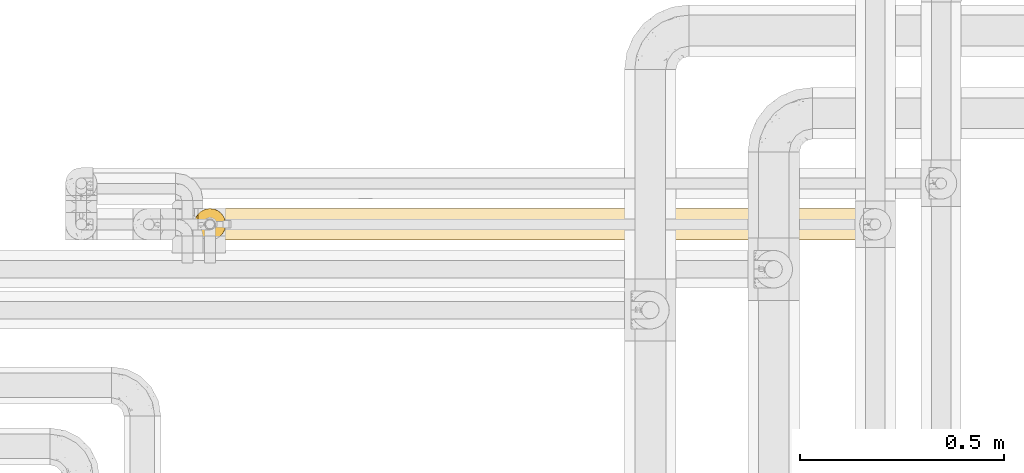
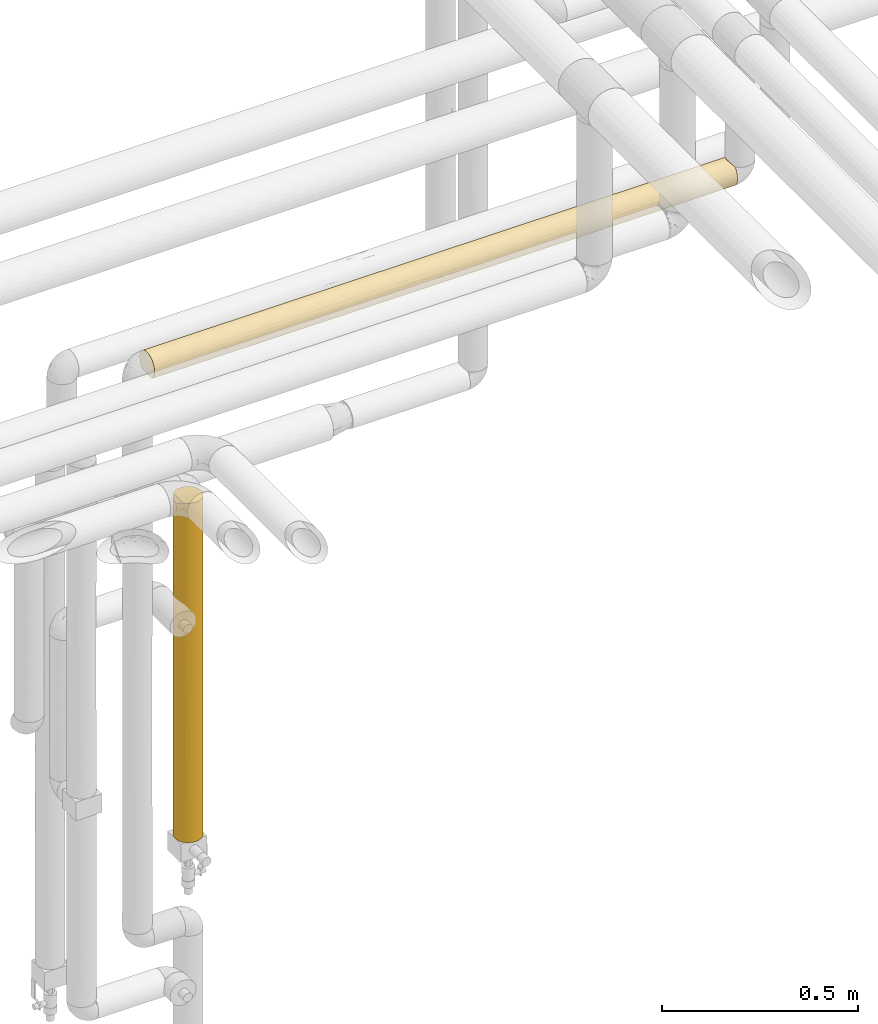
# One storey, part 42 of 827: 2 coverings.
"""IFC2X3 building model written with IfcOpenShell, lengths in millimetres."""

from ifc_helpers import new_model, entity, si_unit, converted_unit, derived_unit, direction, frame, origin, place, context, subcontext, project, spatial, faceted_brep, element, save


model = new_model("IFC2X3")

# Units and contexts
model_context = context("Model", 3, precision=0.01, world=origin(), true_north=direction((6.12303176911189e-17, 1.0)))
body_context = subcontext(model_context, "Body", "Model", "MODEL_VIEW")
ifc_project = project(units=[si_unit("LENGTHUNIT", "METRE", prefix="MILLI"), si_unit("AREAUNIT", "SQUARE_METRE"), si_unit("VOLUMEUNIT", "CUBIC_METRE"), converted_unit("PLANEANGLEUNIT", "DEGREE", entity("IfcRatioMeasure", 0.0174532925199433), si_unit("PLANEANGLEUNIT", "RADIAN"), dimensions=[0, 0, 0, 0, 0, 0, 0]), si_unit("MASSUNIT", "GRAM", prefix="KILO"), derived_unit("MASSDENSITYUNIT", [(si_unit("MASSUNIT", "GRAM", prefix="KILO"), 1), (si_unit("LENGTHUNIT", "METRE"), -3)]), derived_unit("MOMENTOFINERTIAUNIT", [(si_unit("LENGTHUNIT", "METRE"), 4)]), si_unit("TIMEUNIT", "SECOND"), si_unit("FREQUENCYUNIT", "HERTZ"), si_unit("THERMODYNAMICTEMPERATUREUNIT", "DEGREE_CELSIUS"), derived_unit("THERMALTRANSMITTANCEUNIT", [(si_unit("MASSUNIT", "GRAM", prefix="KILO"), 1), (si_unit("THERMODYNAMICTEMPERATUREUNIT", "KELVIN"), -1), (si_unit("TIMEUNIT", "SECOND"), -3)]), derived_unit("VOLUMETRICFLOWRATEUNIT", [(si_unit("LENGTHUNIT", "METRE"), 3), (si_unit("TIMEUNIT", "SECOND"), -1)]), derived_unit("MASSFLOWRATEUNIT", [(si_unit("MASSUNIT", "GRAM", prefix="KILO"), 1), (si_unit("TIMEUNIT", "SECOND"), -1)]), derived_unit("ROTATIONALFREQUENCYUNIT", [(si_unit("TIMEUNIT", "SECOND"), -1)]), si_unit("ELECTRICCURRENTUNIT", "AMPERE"), si_unit("ELECTRICVOLTAGEUNIT", "VOLT"), si_unit("POWERUNIT", "WATT"), si_unit("FORCEUNIT", "NEWTON", prefix="KILO"), si_unit("ILLUMINANCEUNIT", "LUX"), si_unit("LUMINOUSFLUXUNIT", "LUMEN"), si_unit("LUMINOUSINTENSITYUNIT", "CANDELA"), derived_unit("USERDEFINED", [(si_unit("MASSUNIT", "GRAM", prefix="KILO"), -1), (si_unit("LENGTHUNIT", "METRE"), -2), (si_unit("TIMEUNIT", "SECOND"), 3), (si_unit("LUMINOUSFLUXUNIT", "LUMEN"), 1)]), derived_unit("LINEARVELOCITYUNIT", [(si_unit("LENGTHUNIT", "METRE"), 1), (si_unit("TIMEUNIT", "SECOND"), -1)]), si_unit("PRESSUREUNIT", "PASCAL"), derived_unit("USERDEFINED", [(si_unit("LENGTHUNIT", "METRE"), -2), (si_unit("MASSUNIT", "GRAM", prefix="KILO"), 1), (si_unit("TIMEUNIT", "SECOND"), -2)]), derived_unit("LINEARFORCEUNIT", [(si_unit("MASSUNIT", "GRAM", prefix="KILO"), 1), (si_unit("LENGTHUNIT", "METRE"), 1), (si_unit("TIMEUNIT", "SECOND"), -2), (si_unit("LENGTHUNIT", "METRE"), -1)]), derived_unit("PLANARFORCEUNIT", [(si_unit("MASSUNIT", "GRAM", prefix="KILO"), 1), (si_unit("LENGTHUNIT", "METRE"), 1), (si_unit("TIMEUNIT", "SECOND"), -2), (si_unit("LENGTHUNIT", "METRE"), -2)])], contexts=[model_context])

# Site, building, storey
site_placement = place(None, origin())
site = spatial("IfcSite", under=ifc_project, at=site_placement, CompositionType="ELEMENT")
building_placement = place(site_placement, origin())
building = spatial("IfcBuilding", under=site, at=building_placement, CompositionType="ELEMENT")
storey_placement = place(building_placement, frame((0.0, 0.0, 28200.0)))
storey = spatial("IfcBuildingStorey", under=building, at=storey_placement, Name="08", CompositionType="ELEMENT", Elevation=28200.0)

# Coverings
covering_1_placement = place(storey_placement, frame((34717.93, 18294.92, 2960.17)))
element("IfcCovering", 1, at=covering_1_placement, inside=storey, Name=":ADSK_", ObjectType=":ADSK_", PredefinedType="INSULATION", context=body_context, shape_type="Brep", body=[
    faceted_brep([(1721.69, 59.2, 6.74), (1721.69, 67.15, 12.84), (1721.69, 73.25, 20.8), (1721.69, 77.09, 30.06), (1721.69, 78.4, 40.0), (1721.69, 77.51, 48.2), (1721.69, 74.9, 56.01), (1721.69, 70.68, 63.08), (1721.69, 65.05, 69.1), (1721.69, 14.94, 69.1), (1721.69, 9.31, 63.08), (1721.69, 5.09, 56.01), (1721.69, 2.48, 48.2), (1721.69, 1.6, 40.0), (1721.69, 2.9, 30.06), (1721.69, 6.74, 20.8), (1721.69, 12.84, 12.84), (1721.69, 20.8, 6.74), (1721.69, 30.06, 2.9), (1721.69, 40.0, 1.6), (1721.69, 49.93, 2.9), (1.6, 77.09, 49.93), (1.6, 78.4, 40.0), (1.6, 77.51, 31.79), (1.6, 74.9, 23.98), (1.6, 70.68, 16.91), (1.6, 65.05, 10.9), (1.6, 14.94, 10.9), (1.6, 9.31, 16.91), (1.6, 5.09, 23.98), (1.6, 2.48, 31.79), (1.6, 1.6, 40.0), (1.6, 2.9, 49.93), (1.6, 6.74, 59.2), (1.6, 12.84, 67.15), (1.6, 20.8, 73.25), (1.6, 30.06, 77.09), (1.6, 40.0, 78.4), (1.6, 49.93, 77.09), (1.6, 59.2, 73.25), (1.6, 67.15, 67.15), (1.6, 73.25, 59.2), (218.66, 7.01, 20.33), (1181.65, 9.53, 16.62), (1471.1, 9.53, 16.62), (1393.39, 4.52, 25.3), (1402.18, 32.68, 2.3), (1299.04, 40.0, 1.6), (1505.31, 40.0, 1.6), (287.23, 3.58, 27.82), (217.97, 1.6, 40.0), (616.82, 2.85, 30.25), (434.34, 1.6, 40.0), (977.76, 14.18, 11.57), (743.65, 9.87, 16.18), (717.19, 17.22, 9.08), (287.24, 11.96, 13.75), (335.45, 31.75, 2.49), (688.07, 29.53, 3.05), (384.99, 23.31, 5.41), (1199.89, 3.98, 26.66), (939.49, 22.16, 5.99), (1397.13, 2.24, 32.96), (1161.95, 2.21, 33.16), (485.18, 7.01, 20.33), (227.27, 40.0, 1.6), (10.29, 33.21, 2.2), (982.05, 31.09, 2.64), (1187.22, 33.38, 2.17), (1199.75, 25.3, 4.52), (532.41, 12.87, 12.82), (5.57, 20.48, 6.92), (8.5, 26.63, 4.0), (606.06, 22.88, 5.62), (383.25, 16.94, 9.29), (1400.42, 16.62, 9.53), (1480.82, 25.3, 4.52), (1505.31, 1.6, 40.0), (443.64, 40.0, 1.6), (1288.94, 1.6, 40.0), (867.09, 1.6, 40.0), (1002.96, 3.74, 27.35), (10.9, 40.0, 1.6), (1167.6, 18.11, 8.44), (660.01, 40.0, 1.6), (876.39, 40.0, 1.6), (705.79, 5.53, 23.07), (856.2, 1.6, 40.0), (650.71, 1.6, 40.0), (645.28, 1.6, 40.0), (1087.71, 40.0, 1.6), (961.54, 9.06, 17.25), (1078.01, 1.6, 40.0), (1072.57, 1.6, 40.0), (335.45, 48.24, 2.49), (688.07, 50.46, 3.05), (287.24, 68.03, 13.75), (383.25, 63.05, 9.29), (218.66, 72.98, 20.33), (1400.42, 63.37, 9.53), (8.5, 53.36, 4.0), (5.57, 59.51, 6.92), (384.99, 56.68, 5.41), (10.29, 46.78, 2.2), (1161.95, 77.78, 33.16), (1288.94, 78.4, 40.0), (1397.13, 77.75, 32.96), (485.18, 72.98, 20.33), (287.23, 76.41, 27.82), (1480.82, 54.69, 4.52), (1402.18, 47.31, 2.3), (1199.75, 54.69, 4.52), (1471.1, 70.46, 16.62), (1393.39, 75.47, 25.3), (1190.71, 47.68, 2.37), (743.65, 70.12, 16.18), (532.41, 67.12, 12.82), (717.19, 62.77, 9.08), (977.76, 65.82, 11.57), (616.82, 77.14, 30.25), (867.09, 78.4, 40.0), (1072.57, 78.4, 40.0), (1078.01, 78.4, 40.0), (939.49, 57.83, 5.99), (1194.8, 65.31, 11.12), (434.34, 78.4, 40.0), (217.97, 78.4, 40.0), (958.41, 72.6, 19.72), (1199.89, 76.01, 26.66), (1181.65, 70.46, 16.62), (1505.31, 78.4, 40.0), (606.06, 57.11, 5.62), (982.05, 48.9, 2.64), (705.79, 74.47, 23.07), (645.27, 78.4, 40.0), (650.72, 78.4, 40.0), (856.19, 78.4, 40.0), (1002.96, 76.25, 27.35), (252.19, 70.46, 63.37), (329.89, 75.47, 54.69), (1340.03, 63.05, 70.7), (1436.04, 68.03, 66.24), (1190.88, 67.12, 67.17), (523.53, 54.69, 75.47), (321.11, 47.31, 77.69), (532.57, 47.68, 77.62), (783.79, 57.83, 74.0), (528.49, 65.31, 68.87), (242.46, 54.69, 75.47), (322.86, 63.37, 70.46), (1387.83, 48.24, 77.5), (1714.79, 53.36, 76.0), (1338.29, 56.68, 74.58), (1436.05, 76.41, 52.17), (1238.1, 72.98, 59.66), (979.63, 70.12, 63.81), (561.33, 77.78, 46.83), (1504.62, 72.98, 59.66), (326.15, 77.75, 47.03), (1063.27, 40.0, 78.4), (1279.64, 40.0, 78.4), (1035.22, 50.46, 76.94), (846.9, 40.0, 78.4), (1006.09, 62.77, 70.91), (745.52, 65.82, 68.42), (1712.99, 46.78, 77.79), (217.97, 40.0, 78.4), (1717.72, 59.51, 73.07), (1106.47, 77.14, 49.74), (1496.02, 40.0, 78.4), (1712.39, 40.0, 78.4), (764.87, 72.6, 60.27), (523.39, 76.01, 53.33), (541.63, 70.46, 63.37), (635.57, 40.0, 78.4), (424.25, 40.0, 78.4), (1117.22, 57.11, 74.37), (741.23, 48.9, 77.35), (1017.49, 74.47, 56.92), (720.32, 76.25, 52.64), (242.46, 25.3, 75.47), (326.15, 2.24, 47.03), (741.23, 31.09, 77.35), (536.06, 33.38, 77.82), (523.53, 25.3, 75.47), (783.79, 22.16, 74.0), (1035.22, 29.53, 76.94), (541.63, 9.53, 63.37), (252.19, 9.53, 63.37), (329.89, 4.52, 54.69), (1340.03, 16.94, 70.7), (1717.72, 20.48, 73.07), (1338.29, 23.31, 74.58), (322.86, 16.62, 70.46), (1714.79, 26.63, 76.0), (1387.83, 31.75, 77.5), (1712.99, 33.21, 77.79), (321.11, 32.68, 77.69), (1436.04, 11.96, 66.24), (1504.62, 7.01, 59.66), (1238.1, 7.01, 59.66), (1436.05, 3.58, 52.17), (1117.22, 22.88, 74.37), (523.39, 3.98, 53.33), (1006.09, 17.22, 70.91), (979.63, 9.87, 63.81), (1190.88, 12.87, 67.17), (745.52, 14.18, 68.42), (1106.47, 2.85, 49.74), (561.33, 2.21, 46.83), (720.32, 3.74, 52.64), (555.69, 18.11, 71.55), (1017.49, 5.53, 56.92), (761.75, 9.06, 62.74)], [[[0, 1, 2, 3, 4, 5, 6, 7, 8, 9, 10, 11, 12, 13, 14, 15, 16, 17, 18, 19, 20]], [[21, 22, 23, 24, 25, 26, 27, 28, 29, 30, 31, 32, 33, 34, 35, 36, 37, 38, 39, 40, 41]], [[42, 29, 28]], [[43, 44, 45]], [[46, 47, 48]], [[49, 50, 30]], [[49, 51, 52]], [[53, 54, 55]], [[56, 42, 28]], [[57, 58, 59]], [[45, 60, 43]], [[55, 61, 53]], [[60, 62, 63]], [[15, 14, 45]], [[42, 64, 49]], [[29, 49, 30]], [[65, 57, 66]], [[16, 15, 44]], [[67, 68, 69]], [[27, 56, 28]], [[55, 54, 70]], [[59, 71, 72]], [[61, 73, 58]], [[59, 74, 71]], [[61, 58, 67]], [[75, 69, 76]], [[76, 18, 17]], [[17, 16, 75]], [[14, 13, 77]], [[65, 78, 57]], [[74, 27, 71]], [[72, 66, 57]], [[74, 55, 70]], [[51, 49, 64]], [[45, 44, 15]], [[62, 77, 79]], [[63, 80, 81]], [[66, 82, 65]], [[44, 75, 16]], [[18, 48, 19]], [[43, 53, 83]], [[58, 78, 84, 85]], [[57, 59, 72]], [[61, 67, 69]], [[73, 59, 58]], [[51, 81, 80]], [[56, 70, 64]], [[64, 54, 86]], [[51, 80, 87, 88, 89, 52]], [[50, 49, 52]], [[50, 31, 30]], [[75, 44, 43]], [[75, 76, 17]], [[46, 18, 76]], [[90, 68, 67]], [[18, 46, 48]], [[69, 46, 76]], [[90, 67, 85]], [[46, 68, 47]], [[58, 85, 67]], [[69, 75, 83]], [[61, 55, 73]], [[61, 69, 83]], [[91, 54, 53]], [[91, 53, 43]], [[64, 86, 51]], [[63, 62, 79]], [[77, 62, 14]], [[14, 62, 45]], [[63, 79, 92, 93, 80]], [[60, 63, 81]], [[60, 81, 91]], [[62, 60, 45]], [[64, 70, 54]], [[74, 70, 56]], [[74, 56, 27]], [[74, 59, 73]], [[91, 86, 54]], [[81, 51, 86]], [[64, 42, 56]], [[29, 42, 49]], [[78, 58, 57]], [[74, 73, 55]], [[47, 68, 90]], [[69, 68, 46]], [[43, 83, 75]], [[61, 83, 53]], [[60, 91, 43]], [[86, 91, 81]], [[78, 94, 95]], [[96, 97, 26]], [[25, 98, 96]], [[0, 99, 1]], [[25, 96, 26]], [[100, 101, 102]], [[103, 100, 94]], [[104, 105, 106]], [[107, 96, 98]], [[108, 98, 24]], [[20, 19, 48]], [[94, 100, 102]], [[109, 110, 111]], [[2, 112, 113]], [[109, 99, 0]], [[111, 110, 114]], [[107, 115, 116]], [[84, 78, 95, 85]], [[65, 82, 103]], [[113, 3, 2]], [[108, 24, 23]], [[0, 20, 109]], [[117, 115, 118]], [[97, 96, 116]], [[2, 1, 112]], [[107, 108, 119]], [[106, 3, 113]], [[104, 120, 121, 122, 105]], [[123, 124, 111]], [[125, 108, 126]], [[78, 65, 94]], [[97, 101, 26]], [[108, 23, 126]], [[119, 108, 125]], [[127, 128, 129]], [[3, 130, 4]], [[124, 123, 118]], [[90, 114, 47]], [[99, 124, 112]], [[103, 94, 65]], [[94, 102, 95]], [[102, 131, 95]], [[132, 123, 111]], [[127, 118, 115]], [[115, 107, 133]], [[119, 125, 134, 135, 136, 120]], [[137, 119, 120]], [[23, 22, 126]], [[99, 112, 1]], [[113, 112, 129]], [[48, 110, 20]], [[99, 109, 111]], [[110, 48, 47]], [[132, 90, 85]], [[20, 110, 109]], [[132, 111, 114]], [[85, 95, 132]], [[95, 131, 123]], [[95, 123, 132]], [[118, 123, 117]], [[117, 116, 115]], [[124, 118, 129]], [[133, 107, 119]], [[127, 137, 128]], [[3, 106, 130]], [[105, 130, 106]], [[104, 128, 137]], [[128, 106, 113]], [[120, 104, 137]], [[106, 128, 104]], [[129, 128, 113]], [[117, 131, 97]], [[107, 116, 96]], [[117, 97, 116]], [[101, 97, 102]], [[119, 137, 133]], [[127, 133, 137]], [[24, 98, 25]], [[107, 98, 108]], [[97, 131, 102]], [[123, 131, 117]], [[47, 114, 110]], [[90, 132, 114]], [[112, 124, 129]], [[111, 124, 99]], [[118, 127, 129]], [[133, 127, 115]], [[41, 40, 138]], [[41, 138, 139]], [[140, 141, 142]], [[143, 144, 145]], [[146, 147, 143]], [[39, 148, 149]], [[150, 151, 152]], [[139, 21, 41]], [[105, 153, 130]], [[154, 155, 142]], [[156, 136, 135, 134, 125]], [[154, 141, 157]], [[148, 39, 38]], [[156, 125, 158]], [[153, 157, 6]], [[159, 160, 161, 162]], [[163, 155, 164]], [[165, 151, 150]], [[158, 21, 139]], [[141, 140, 8]], [[38, 37, 166]], [[7, 157, 141]], [[150, 161, 160]], [[7, 141, 8]], [[167, 152, 151]], [[39, 149, 40]], [[154, 153, 168]], [[148, 144, 143]], [[169, 170, 165]], [[153, 6, 5]], [[160, 169, 150]], [[140, 167, 8]], [[153, 5, 130]], [[168, 153, 105]], [[171, 172, 173]], [[21, 126, 22]], [[147, 146, 164]], [[174, 145, 175]], [[149, 147, 138]], [[165, 150, 169]], [[150, 152, 161]], [[152, 176, 161]], [[177, 146, 143]], [[171, 164, 155]], [[155, 154, 178]], [[168, 105, 122, 121, 120, 136]], [[179, 168, 136]], [[5, 4, 130]], [[149, 138, 40]], [[139, 138, 173]], [[166, 144, 38]], [[149, 148, 143]], [[144, 166, 175]], [[177, 174, 162]], [[38, 144, 148]], [[177, 143, 145]], [[162, 161, 177]], [[161, 176, 146]], [[161, 146, 177]], [[164, 146, 163]], [[163, 142, 155]], [[147, 164, 173]], [[178, 154, 168]], [[171, 179, 172]], [[21, 158, 126]], [[125, 126, 158]], [[156, 172, 179]], [[172, 158, 139]], [[136, 156, 179]], [[158, 172, 156]], [[173, 172, 139]], [[163, 176, 140]], [[154, 142, 141]], [[163, 140, 142]], [[167, 140, 152]], [[168, 179, 178]], [[171, 178, 179]], [[6, 157, 7]], [[154, 157, 153]], [[140, 176, 152]], [[146, 176, 163]], [[175, 145, 144]], [[174, 177, 145]], [[138, 147, 173]], [[143, 147, 149]], [[164, 171, 173]], [[178, 171, 155]], [[35, 180, 36]], [[52, 181, 50]], [[182, 183, 184]], [[185, 186, 182]], [[187, 188, 189]], [[190, 191, 192]], [[193, 184, 180]], [[191, 194, 192]], [[34, 33, 188]], [[169, 195, 196]], [[197, 175, 166]], [[9, 198, 10]], [[199, 200, 201]], [[201, 77, 12]], [[195, 186, 192]], [[185, 202, 186]], [[190, 9, 191]], [[189, 203, 187]], [[194, 196, 195]], [[198, 199, 10]], [[204, 205, 206]], [[207, 205, 204]], [[11, 201, 12]], [[204, 185, 207]], [[199, 11, 10]], [[201, 208, 79]], [[33, 32, 189]], [[169, 160, 195]], [[35, 34, 193]], [[209, 203, 181]], [[190, 204, 206]], [[208, 201, 200]], [[12, 77, 13]], [[32, 50, 181]], [[209, 87, 210]], [[196, 170, 169]], [[188, 193, 34]], [[36, 166, 37]], [[187, 207, 211]], [[186, 160, 159, 162]], [[195, 192, 194]], [[185, 182, 184]], [[202, 192, 186]], [[208, 210, 87]], [[198, 206, 200]], [[200, 205, 212]], [[208, 87, 80, 93, 92, 79]], [[189, 188, 33]], [[79, 77, 201]], [[193, 188, 187]], [[193, 180, 35]], [[197, 36, 180]], [[174, 183, 182]], [[36, 197, 166]], [[184, 197, 180]], [[174, 182, 162]], [[197, 183, 175]], [[186, 162, 182]], [[184, 193, 211]], [[185, 204, 202]], [[185, 184, 211]], [[213, 205, 207]], [[213, 207, 187]], [[200, 212, 208]], [[32, 31, 50]], [[209, 181, 52]], [[32, 181, 189]], [[209, 52, 89, 88, 87]], [[203, 209, 210]], [[203, 210, 213]], [[181, 203, 189]], [[200, 206, 205]], [[190, 206, 198]], [[190, 198, 9]], [[190, 192, 202]], [[213, 212, 205]], [[210, 208, 212]], [[200, 199, 198]], [[11, 199, 201]], [[160, 186, 195]], [[190, 202, 204]], [[175, 183, 174]], [[184, 183, 197]], [[187, 211, 193]], [[185, 211, 207]], [[203, 213, 187]], [[212, 213, 210]], [[165, 170, 196, 194, 191, 9, 8, 167, 151]], [[26, 101, 100, 103, 82, 66, 72, 71, 27]]]),
])
covering_2_placement = place(storey_placement, frame((34800.43, 18294.92, 1492.5)))
element("IfcCovering", 2, at=covering_2_placement, inside=storey, Name=":ADSK_", ObjectType=":ADSK_", PredefinedType="INSULATION", context=body_context, shape_type="Brep", body=[
    faceted_brep([(2.9, 30.06, 0.0), (1.6, 40.0, 0.0), (2.9, 49.93, 0.0), (6.74, 59.2, 0.0), (12.84, 67.15, 0.0), (20.8, 73.25, 0.0), (30.06, 77.09, 0.0), (40.0, 78.4, 0.0), (49.93, 77.09, 0.0), (59.2, 73.25, 0.0), (67.15, 67.15, 0.0), (73.25, 59.2, 0.0), (77.09, 49.93, 0.0), (78.4, 40.0, 0.0), (77.09, 30.06, 0.0), (73.25, 20.8, 0.0), (67.15, 12.84, 0.0), (59.2, 6.74, 0.0), (49.93, 2.9, 0.0), (40.0, 1.6, 0.0), (30.06, 2.9, 0.0), (20.8, 6.74, 0.0), (12.84, 12.84, 0.0), (6.74, 20.8, 0.0), (10.9, 14.94, 1058.4), (16.91, 9.31, 1058.4), (23.98, 5.09, 1058.4), (31.79, 2.48, 1058.4), (40.0, 1.6, 1058.4), (49.93, 2.9, 1058.4), (59.2, 6.74, 1058.4), (67.15, 12.84, 1058.4), (73.25, 20.8, 1058.4), (77.09, 30.06, 1058.4), (78.4, 40.0, 1058.4), (77.09, 49.93, 1058.4), (73.25, 59.2, 1058.4), (67.15, 67.15, 1058.4), (59.2, 73.25, 1058.4), (49.93, 77.09, 1058.4), (40.0, 78.4, 1058.4), (31.79, 77.51, 1058.4), (23.98, 74.9, 1058.4), (16.91, 70.68, 1058.4), (10.9, 65.05, 1058.4), (70.46, 16.62, 813.62), (78.4, 40.0, 312.83), (77.64, 32.43, 237.31), (75.01, 24.24, 875.18), (76.93, 29.5, 733.84), (78.4, 40.0, 842.03), (70.46, 16.62, 244.78), (47.2, 2.28, 733.84), (46.91, 2.22, 494.82), (54.69, 4.52, 446.97), (78.4, 40.0, 625.65), (74.0, 22.15, 671.41), (77.68, 32.64, 469.24), (75.47, 25.3, 324.07), (70.46, 16.62, 529.2), (63.37, 9.53, 734.33), (40.0, 1.6, 625.65), (63.37, 9.53, 293.9), (56.85, 5.49, 225.61), (54.69, 4.52, 799.25), (65.03, 10.88, 514.11), (49.37, 2.76, 252.44), (40.0, 1.6, 842.03), (40.0, 1.6, 432.75), (40.0, 1.6, 312.83), (40.0, 1.6, 216.37), (20.33, 7.01, 855.36), (27.82, 3.58, 790.86), (20.33, 7.01, 620.07), (14.36, 11.4, 737.71), (14.56, 11.23, 498.2), (25.3, 4.52, 313.84), (2.98, 29.79, 742.51), (2.33, 32.52, 462.27), (4.6, 25.11, 549.47), (16.62, 9.53, 257.2), (8.89, 17.48, 800.36), (2.2, 33.21, 1049.7), (1.6, 40.0, 832.73), (32.83, 2.27, 308.29), (2.33, 32.5, 231.69), (1.6, 40.0, 308.18), (31.06, 2.65, 529.2), (4.0, 26.63, 1051.5), (5.45, 23.23, 742.57), (9.53, 16.62, 243.7), (4.52, 25.3, 309.55), (9.0, 17.32, 526.07), (1.6, 40.0, 616.36), (1.6, 40.0, 432.75), (6.92, 20.48, 1054.43), (1.6, 40.0, 216.37), (1.6, 40.0, 1049.1), (5.36, 56.59, 867.73), (4.0, 53.36, 1051.5), (6.92, 59.51, 1054.43), (2.2, 46.78, 1049.7), (2.98, 50.2, 742.51), (4.52, 54.69, 309.55), (9.53, 63.37, 243.7), (8.89, 62.51, 800.36), (2.25, 47.04, 324.56), (3.31, 51.35, 515.31), (9.0, 62.67, 526.07), (14.36, 68.59, 737.71), (20.33, 72.98, 855.36), (40.0, 78.4, 625.65), (40.0, 78.4, 432.74), (31.06, 77.34, 529.2), (27.82, 76.41, 790.86), (5.63, 57.12, 658.7), (20.33, 72.98, 620.07), (40.0, 78.4, 216.37), (32.83, 77.72, 308.29), (25.3, 75.47, 313.84), (16.62, 70.46, 257.2), (40.0, 78.4, 842.02), (14.56, 68.76, 498.2), (40.0, 78.4, 745.57), (63.37, 70.46, 813.62), (54.69, 75.47, 734.33), (63.37, 70.46, 244.78), (70.46, 63.37, 293.9), (69.11, 65.03, 514.11), (75.47, 54.69, 446.97), (54.69, 75.47, 324.07), (56.97, 74.44, 529.2), (47.36, 77.68, 588.94), (47.03, 77.75, 324.56), (70.46, 63.37, 734.33), (77.23, 49.37, 252.44), (77.71, 47.2, 733.84), (77.77, 46.91, 494.82), (47.56, 77.64, 820.76), (74.5, 56.85, 225.61), (63.37, 70.46, 529.2), (75.47, 54.69, 799.25)], [[[0, 1, 2, 3, 4, 5, 6, 7, 8, 9, 10, 11, 12, 13, 14, 15, 16, 17, 18, 19, 20, 21, 22, 23]], [[24, 25, 26, 27, 28, 29, 30, 31, 32, 33, 34, 35, 36, 37, 38, 39, 40, 41, 42, 43, 44]], [[32, 31, 45]], [[13, 46, 47]], [[48, 33, 32]], [[49, 50, 33]], [[15, 51, 16]], [[52, 53, 54]], [[50, 34, 33]], [[49, 55, 50]], [[56, 57, 49]], [[48, 45, 56]], [[14, 58, 15]], [[59, 45, 60]], [[52, 61, 53]], [[62, 17, 16]], [[58, 57, 56]], [[54, 63, 62]], [[31, 30, 60]], [[60, 30, 64]], [[65, 54, 62]], [[54, 66, 63]], [[53, 66, 54]], [[64, 30, 29]], [[55, 57, 46]], [[61, 52, 67]], [[51, 62, 16]], [[59, 51, 58]], [[18, 66, 19]], [[60, 65, 59]], [[67, 52, 29]], [[54, 60, 64]], [[46, 57, 47]], [[60, 45, 31]], [[56, 45, 59]], [[58, 51, 15]], [[51, 59, 65]], [[29, 28, 67]], [[54, 64, 52]], [[29, 52, 64]], [[53, 61, 68, 69]], [[66, 69, 70, 19]], [[69, 66, 53]], [[63, 18, 17]], [[18, 63, 66]], [[17, 62, 63]], [[49, 57, 55]], [[47, 57, 58]], [[58, 14, 47]], [[13, 47, 14]], [[58, 56, 59]], [[48, 56, 49]], [[33, 48, 49]], [[45, 48, 32]], [[54, 65, 60]], [[51, 65, 62]], [[71, 72, 26]], [[73, 74, 75]], [[76, 21, 20]], [[77, 78, 79]], [[73, 80, 76]], [[74, 24, 81]], [[82, 83, 77]], [[27, 72, 67]], [[26, 72, 27]], [[22, 21, 80]], [[20, 70, 84]], [[85, 78, 86]], [[74, 73, 71]], [[76, 87, 73]], [[88, 77, 89]], [[76, 80, 21]], [[71, 26, 25]], [[23, 22, 90]], [[77, 88, 82]], [[72, 61, 67]], [[79, 89, 77]], [[23, 90, 91]], [[92, 75, 74]], [[78, 93, 94, 86]], [[91, 0, 23]], [[95, 88, 89]], [[84, 68, 87]], [[95, 81, 24]], [[87, 61, 72]], [[78, 85, 91]], [[68, 61, 87]], [[28, 27, 67]], [[73, 87, 72]], [[78, 77, 93]], [[0, 85, 1]], [[80, 75, 90]], [[25, 24, 74]], [[72, 71, 73]], [[25, 74, 71]], [[92, 74, 81]], [[80, 90, 22]], [[91, 90, 92]], [[90, 75, 92]], [[80, 73, 75]], [[20, 19, 70]], [[87, 76, 84]], [[78, 91, 79]], [[91, 92, 79]], [[89, 92, 81]], [[85, 86, 96, 1]], [[0, 91, 85]], [[92, 89, 79]], [[89, 81, 95]], [[20, 84, 76]], [[84, 70, 69, 68]], [[83, 82, 97]], [[83, 93, 77]], [[98, 99, 100]], [[101, 99, 102]], [[103, 3, 2]], [[4, 3, 104]], [[97, 101, 83]], [[100, 44, 105]], [[101, 102, 83]], [[103, 106, 107]], [[108, 105, 109]], [[110, 109, 43]], [[107, 93, 102]], [[111, 112, 113]], [[106, 96, 86, 94]], [[2, 96, 106]], [[114, 42, 41]], [[103, 107, 115]], [[110, 114, 116]], [[112, 117, 118]], [[119, 6, 5]], [[98, 105, 115]], [[120, 116, 119]], [[44, 43, 109]], [[113, 114, 111]], [[120, 119, 5]], [[4, 120, 5]], [[108, 103, 115]], [[110, 43, 42]], [[104, 103, 108]], [[119, 113, 118]], [[113, 116, 114]], [[6, 117, 7]], [[116, 113, 119]], [[41, 121, 114]], [[104, 120, 4]], [[122, 108, 109]], [[114, 110, 42]], [[109, 110, 116]], [[109, 116, 122]], [[109, 105, 44]], [[103, 104, 3]], [[104, 108, 122]], [[116, 120, 122]], [[104, 122, 120]], [[2, 1, 96]], [[94, 93, 107]], [[2, 106, 103]], [[107, 106, 94]], [[107, 102, 115]], [[98, 102, 99]], [[105, 108, 115]], [[105, 98, 100]], [[102, 98, 115]], [[118, 6, 119]], [[112, 118, 113]], [[6, 118, 117]], [[102, 93, 83]], [[121, 41, 40]], [[114, 121, 123, 111]], [[124, 125, 38]], [[126, 127, 10]], [[128, 129, 127]], [[130, 131, 126]], [[38, 125, 39]], [[125, 131, 132]], [[37, 124, 38]], [[112, 133, 117]], [[126, 10, 9]], [[9, 8, 130]], [[36, 134, 37]], [[12, 135, 13]], [[136, 55, 137]], [[131, 125, 124]], [[132, 138, 125]], [[129, 139, 127]], [[135, 139, 129]], [[127, 11, 10]], [[140, 124, 134]], [[55, 136, 50]], [[137, 135, 129]], [[141, 134, 36]], [[8, 117, 133]], [[130, 133, 132]], [[141, 36, 35]], [[136, 137, 129]], [[134, 128, 140]], [[50, 136, 35]], [[39, 138, 40]], [[129, 134, 141]], [[130, 126, 9]], [[126, 140, 128]], [[134, 124, 37]], [[124, 140, 126, 131]], [[8, 7, 117]], [[133, 112, 132]], [[8, 133, 130]], [[132, 112, 111, 123]], [[138, 132, 123]], [[35, 34, 50]], [[129, 141, 136]], [[35, 136, 141]], [[55, 46, 137]], [[46, 13, 135]], [[46, 135, 137]], [[139, 12, 11]], [[12, 139, 135]], [[11, 127, 139]], [[138, 123, 121, 40]], [[39, 125, 138]], [[132, 131, 130]], [[129, 128, 134]], [[126, 128, 127]], [[101, 97, 82, 88, 95, 24, 44, 100, 99]]]),
])

save(model, "model.ifc")
